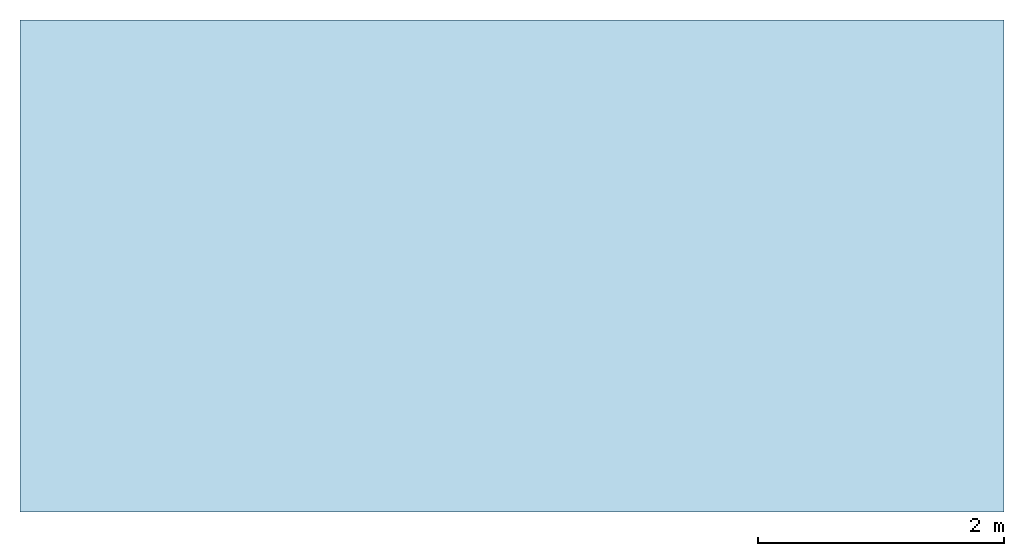
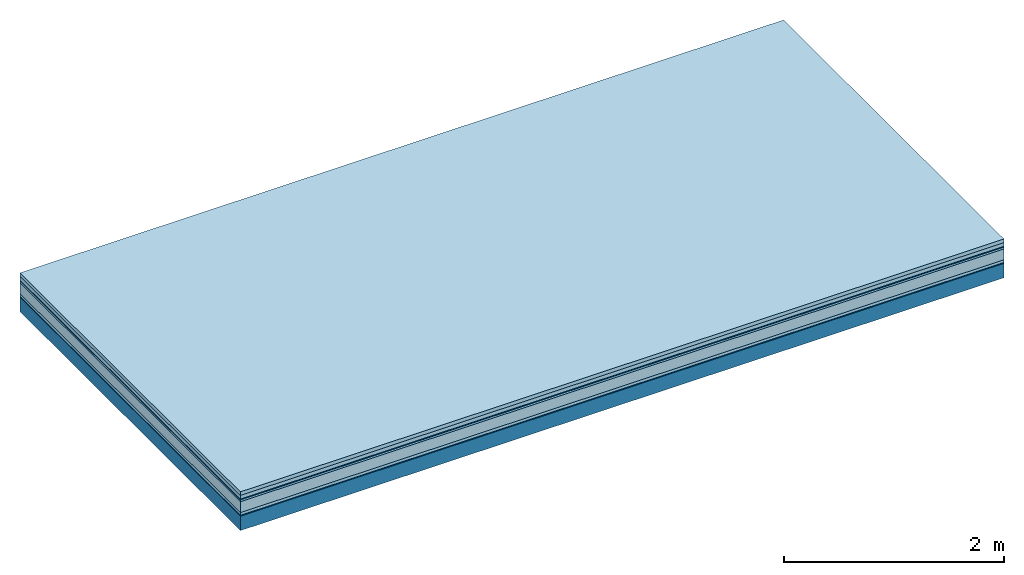
# One storey: 7 plates, 1 member, 1 element without a shape of its own.
"""IFC4 building model written with IfcOpenShell, lengths in metres."""

from ifc_helpers import new_model, si_unit, derived_unit, direction, frame, frame_2d, origin, origin_with_axes, place, context, project, spatial, rectangle, extrude, material, layer, layer_set, type_object, element, aggregate, save


model = new_model("IFC4")

# Units and contexts
plan_context = context("Plan", 3, precision=1e-05, world=origin(), true_north=direction((0.0, 1.0)))
model_context = context("Model", 3, precision=1e-05, world=origin(), true_north=direction((0.0, 1.0)))
ifc_project = project(units=[si_unit("LENGTHUNIT", "METRE"), derived_unit("SOUNDPRESSUREUNIT", [(si_unit("PRESSUREUNIT", "PASCAL", prefix="MICRO"), 0)]), si_unit("ENERGYUNIT", "JOULE", prefix="MEGA"), si_unit("MASSUNIT", "GRAM", prefix="KILO"), derived_unit("THERMALTRANSMITTANCEUNIT", [(si_unit("POWERUNIT", "WATT"), 1), (si_unit("AREAUNIT", "SQUARE_METRE"), -1), (si_unit("THERMODYNAMICTEMPERATUREUNIT", "KELVIN"), -1)]), derived_unit("AREADENSITYUNIT", [(si_unit("MASSUNIT", "GRAM", prefix="KILO"), 1), (si_unit("AREAUNIT", "SQUARE_METRE"), -1)]), derived_unit("USERDEFINED", [(si_unit("ENERGYUNIT", "JOULE", prefix="MEGA"), 1), (si_unit("AREAUNIT", "SQUARE_METRE"), -1)])], contexts=[plan_context, model_context])

# Site, building, storey
site = spatial("IfcSite", under=ifc_project)
building_placement = place(None, origin())
building = spatial("IfcBuilding", under=site, at=building_placement)
storey_placement = place(building_placement, origin())
storey = spatial("IfcBuildingStorey", under=building, at=storey_placement)

# Slab, member, plates
ifc_material_1 = material(Name="Garden plates", Category="02.007")
ifc_layer_1 = layer(ifc_material_1, 0.04, Name="Use and protection layer 3")
ifc_material_2 = material(Name="Gravel 8-16mm", Category="03.011")
ifc_layer_2 = layer(ifc_material_2, 0.04, Name="Use and protection layer 2")
ifc_material_3 = material(Name="Protective layer", Category="09.007")
ifc_layer_3 = layer(ifc_material_3, 0.01, Name="Use and protection layer 1")
ifc_material_4 = material(Name="Bituminous", Category="09.003")
ifc_layer_4 = layer(ifc_material_4, 0.02, Name="Seal")
ifc_material_5 = material(Category="10.006")
ifc_layer_5 = layer(ifc_material_5, 0.12, Name="Exterior insulation layer 2")
ifc_material_6 = material(Name="(034) 25 boards", Category="10.004")
ifc_layer_6 = layer(ifc_material_6, 0.03, Name="Exterior insulation layer 1")
ifc_material_7 = material(Name="Vapor-permeable barrier", Category="09.006")
ifc_layer_7 = layer(ifc_material_7, 0.01, Name="layer / temporary roof")
ifc_material_8 = material(Name="no composite action")
ifc_layer_8 = layer(ifc_material_8, 0.0, Name="Bond")
ifc_layer_9 = layer(None, 0.16, Name="Support")
ifc_layer_set = layer_set([ifc_layer_1, ifc_layer_2, ifc_layer_3, ifc_layer_4, ifc_layer_5, ifc_layer_6, ifc_layer_7, ifc_layer_8, ifc_layer_9])
slab_type = type_object("IfcSlabType", Name="F0060", PredefinedType="NOTDEFINED", material=ifc_layer_set)
slab_placement = place(None, frame((0.0, 0.0, 0.0), z_axis=(0.0, 0.0, -1.0), x_axis=(1.0, 0.0, 0.0)))
slab = element("IfcSlab", 1, at=slab_placement, inside=storey, type_object=slab_type, material=ifc_layer_set, Name="Slab #1")
ifc_material_9 = material(Name="Solid timber panel")
member_placement = place(slab_placement, origin())
member = element("IfcMember", 2, at=member_placement, material=ifc_material_9, Name="Support", context=plan_context, shape_type="SweptSolid", body=[
    extrude(rectangle(XDim=1.0, YDim=0.16, at=frame_2d((0.5, 0.08), x_axis=(1.0, 0.0))), frame((0.0, 4.0, 0.27), z_axis=(0.0, -1.0, 0.0), x_axis=(1.0, 0.0, 0.0)), (0.0, 0.0, 1.0), 4.0),
    extrude(rectangle(XDim=1.0, YDim=0.16, at=frame_2d((0.5, 0.08), x_axis=(1.0, 0.0))), frame((1.0, 4.0, 0.27), z_axis=(0.0, -1.0, 0.0), x_axis=(1.0, 0.0, 0.0)), (0.0, 0.0, 1.0), 4.0),
    extrude(rectangle(XDim=1.0, YDim=0.16, at=frame_2d((0.5, 0.08), x_axis=(1.0, 0.0))), frame((2.0, 4.0, 0.27), z_axis=(0.0, -1.0, 0.0), x_axis=(1.0, 0.0, 0.0)), (0.0, 0.0, 1.0), 4.0),
    extrude(rectangle(XDim=1.0, YDim=0.16, at=frame_2d((0.5, 0.08), x_axis=(1.0, 0.0))), frame((3.0, 4.0, 0.27), z_axis=(0.0, -1.0, 0.0), x_axis=(1.0, 0.0, 0.0)), (0.0, 0.0, 1.0), 4.0),
    extrude(rectangle(XDim=1.0, YDim=0.16, at=frame_2d((0.5, 0.08), x_axis=(1.0, 0.0))), frame((4.0, 4.0, 0.27), z_axis=(0.0, -1.0, 0.0), x_axis=(1.0, 0.0, 0.0)), (0.0, 0.0, 1.0), 4.0),
    extrude(rectangle(XDim=1.0, YDim=0.16, at=frame_2d((0.5, 0.08), x_axis=(1.0, 0.0))), frame((5.0, 4.0, 0.27), z_axis=(0.0, -1.0, 0.0), x_axis=(1.0, 0.0, 0.0)), (0.0, 0.0, 1.0), 4.0),
    extrude(rectangle(XDim=1.0, YDim=0.16, at=frame_2d((0.5, 0.08), x_axis=(1.0, 0.0))), frame((6.0, 4.0, 0.27), z_axis=(0.0, -1.0, 0.0), x_axis=(1.0, 0.0, 0.0)), (0.0, 0.0, 1.0), 4.0),
    extrude(rectangle(XDim=1.0, YDim=0.16, at=frame_2d((0.5, 0.08), x_axis=(1.0, 0.0))), frame((7.0, 4.0, 0.27), z_axis=(0.0, -1.0, 0.0), x_axis=(1.0, 0.0, 0.0)), (0.0, 0.0, 1.0), 4.0),
])
plate_1_placement = place(slab_placement, origin())
plate_1 = element("IfcPlate", 3, at=plate_1_placement, material=ifc_material_1, Name="Use and protection layer 3", context=plan_context, shape_type="SweptSolid", body=[
    extrude(rectangle(XDim=8.0, YDim=4.0, at=frame_2d((4.0, 2.0), x_axis=(1.0, 0.0))), origin_with_axes(), (0.0, 0.0, 1.0), 0.04),
])
plate_2_placement = place(slab_placement, origin())
plate_2 = element("IfcPlate", 4, at=plate_2_placement, material=ifc_material_2, Name="Use and protection layer 2", context=plan_context, shape_type="SweptSolid", body=[
    extrude(rectangle(XDim=8.0, YDim=4.0, at=frame_2d((4.0, 2.0), x_axis=(1.0, 0.0))), frame((0.0, 0.0, 0.04), z_axis=(0.0, 0.0, 1.0), x_axis=(1.0, 0.0, 0.0)), (0.0, 0.0, 1.0), 0.04),
])
plate_3_placement = place(slab_placement, origin())
plate_3 = element("IfcPlate", 5, at=plate_3_placement, material=ifc_material_3, Name="Use and protection layer 1", context=plan_context, shape_type="SweptSolid", body=[
    extrude(rectangle(XDim=8.0, YDim=4.0, at=frame_2d((4.0, 2.0), x_axis=(1.0, 0.0))), frame((0.0, 0.0, 0.08), z_axis=(0.0, 0.0, 1.0), x_axis=(1.0, 0.0, 0.0)), (0.0, 0.0, 1.0), 0.01),
])
plate_4_placement = place(slab_placement, origin())
plate_4 = element("IfcPlate", 6, at=plate_4_placement, material=ifc_material_4, Name="Seal", context=plan_context, shape_type="SweptSolid", body=[
    extrude(rectangle(XDim=8.0, YDim=4.0, at=frame_2d((4.0, 2.0), x_axis=(1.0, 0.0))), frame((0.0, 0.0, 0.09), z_axis=(0.0, 0.0, 1.0), x_axis=(1.0, 0.0, 0.0)), (0.0, 0.0, 1.0), 0.02),
])
plate_5_placement = place(slab_placement, origin())
plate_5 = element("IfcPlate", 7, at=plate_5_placement, material=ifc_material_5, Name="Exterior insulation layer 2", context=plan_context, shape_type="SweptSolid", body=[
    extrude(rectangle(XDim=8.0, YDim=4.0, at=frame_2d((4.0, 2.0), x_axis=(1.0, 0.0))), frame((0.0, 0.0, 0.11), z_axis=(0.0, 0.0, 1.0), x_axis=(1.0, 0.0, 0.0)), (0.0, 0.0, 1.0), 0.12),
])
plate_6_placement = place(slab_placement, origin())
plate_6 = element("IfcPlate", 8, at=plate_6_placement, material=ifc_material_6, Name="Exterior insulation layer 1", context=plan_context, shape_type="SweptSolid", body=[
    extrude(rectangle(XDim=8.0, YDim=4.0, at=frame_2d((4.0, 2.0), x_axis=(1.0, 0.0))), frame((0.0, 0.0, 0.23), z_axis=(0.0, 0.0, 1.0), x_axis=(1.0, 0.0, 0.0)), (0.0, 0.0, 1.0), 0.03),
])
plate_7_placement = place(slab_placement, origin())
plate_7 = element("IfcPlate", 9, at=plate_7_placement, material=ifc_material_7, Name="layer / temporary roof", context=plan_context, shape_type="SweptSolid", body=[
    extrude(rectangle(XDim=8.0, YDim=4.0, at=frame_2d((4.0, 2.0), x_axis=(1.0, 0.0))), frame((0.0, 0.0, 0.26), z_axis=(0.0, 0.0, 1.0), x_axis=(1.0, 0.0, 0.0)), (0.0, 0.0, 1.0), 0.01),
])
aggregate(slab, [plate_1, plate_2, plate_3, plate_4, plate_5, plate_6, plate_7, member])

save(model, "model.ifc")
